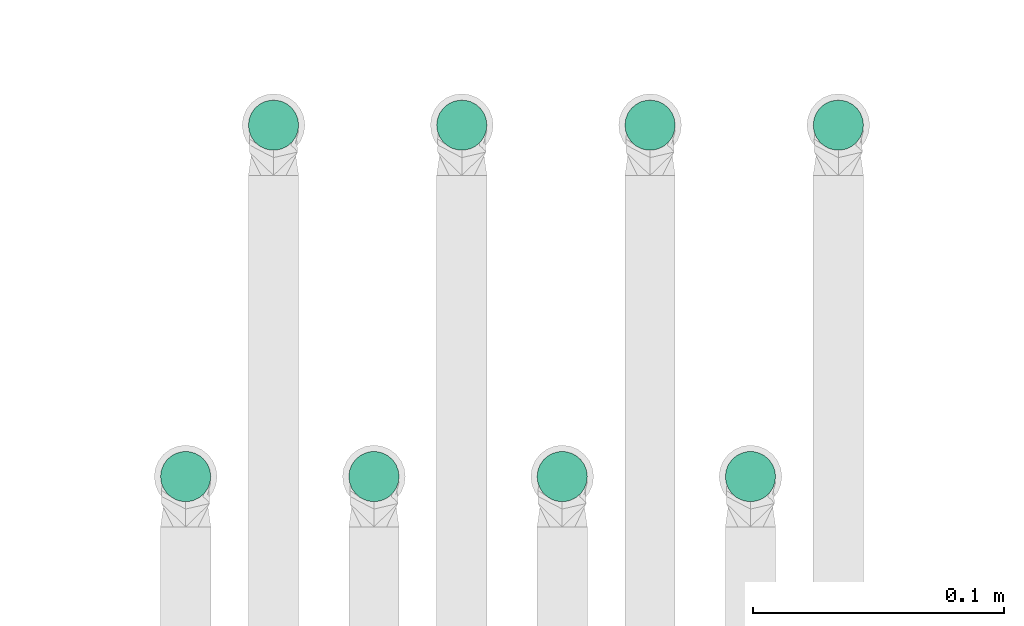
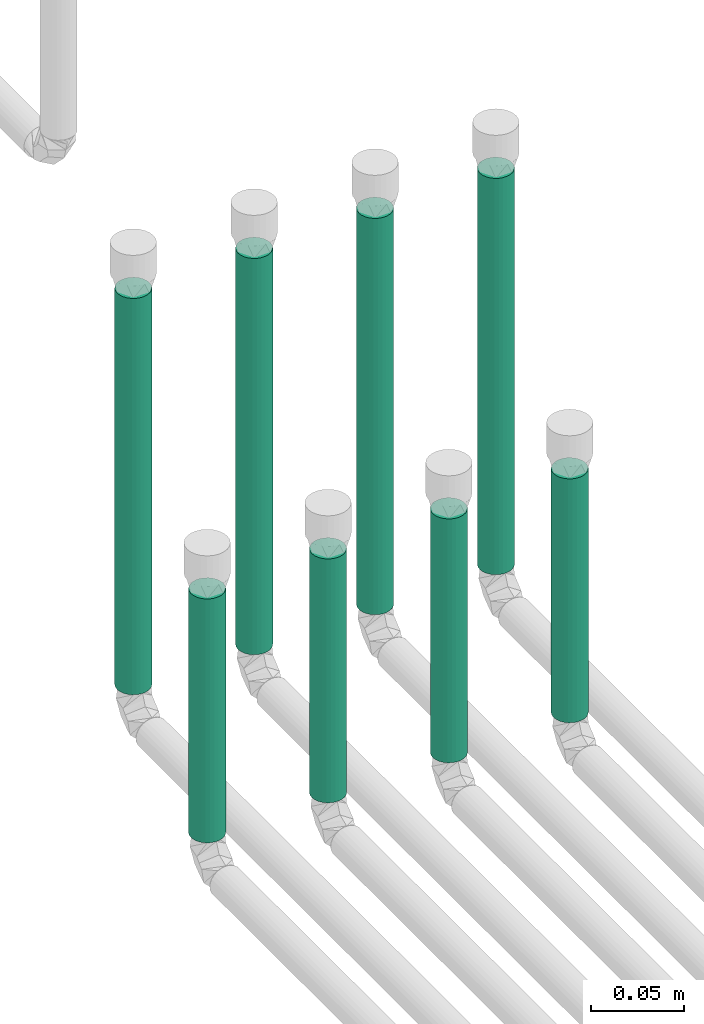
# One storey, part 4 of 12: 8 flow segments.
"""IFC2X3 building model written with IfcOpenShell, lengths in millimetres."""

from ifc_helpers import new_model, entity, si_unit, converted_unit, derived_unit, direction, frame, origin, origin_2d_with_axis, place, context, subcontext, project, spatial, circle, extrude, type_object, element, save


model = new_model("IFC2X3")

# Units and contexts
model_context = context("Model", 3, precision=0.01, world=origin(), true_north=direction((6.12303176911189e-17, 1.0)))
body_context = subcontext(model_context, "Body", "Model", "MODEL_VIEW")
ifc_project = project(units=[si_unit("LENGTHUNIT", "METRE", prefix="MILLI"), si_unit("AREAUNIT", "SQUARE_METRE"), si_unit("VOLUMEUNIT", "CUBIC_METRE"), converted_unit("PLANEANGLEUNIT", "DEGREE", entity("IfcRatioMeasure", 0.0174532925199433), si_unit("PLANEANGLEUNIT", "RADIAN"), dimensions=[0, 0, 0, 0, 0, 0, 0]), si_unit("MASSUNIT", "GRAM", prefix="KILO"), derived_unit("MASSDENSITYUNIT", [(si_unit("MASSUNIT", "GRAM", prefix="KILO"), 1), (si_unit("LENGTHUNIT", "METRE"), -3)]), si_unit("TIMEUNIT", "SECOND"), si_unit("FREQUENCYUNIT", "HERTZ"), si_unit("THERMODYNAMICTEMPERATUREUNIT", "DEGREE_CELSIUS"), derived_unit("THERMALTRANSMITTANCEUNIT", [(si_unit("MASSUNIT", "GRAM", prefix="KILO"), 1), (si_unit("THERMODYNAMICTEMPERATUREUNIT", "KELVIN"), -1), (si_unit("TIMEUNIT", "SECOND"), -3)]), derived_unit("VOLUMETRICFLOWRATEUNIT", [(si_unit("LENGTHUNIT", "METRE"), 3), (si_unit("TIMEUNIT", "SECOND"), -1)]), si_unit("ELECTRICCURRENTUNIT", "AMPERE"), si_unit("ELECTRICVOLTAGEUNIT", "VOLT"), si_unit("POWERUNIT", "WATT"), si_unit("FORCEUNIT", "NEWTON", prefix="KILO"), si_unit("ILLUMINANCEUNIT", "LUX"), si_unit("LUMINOUSFLUXUNIT", "LUMEN"), si_unit("LUMINOUSINTENSITYUNIT", "CANDELA"), derived_unit("USERDEFINED", [(si_unit("MASSUNIT", "GRAM", prefix="KILO"), -1), (si_unit("LENGTHUNIT", "METRE"), -2), (si_unit("TIMEUNIT", "SECOND"), 3), (si_unit("LUMINOUSFLUXUNIT", "LUMEN"), 1)]), derived_unit("LINEARVELOCITYUNIT", [(si_unit("LENGTHUNIT", "METRE"), 1), (si_unit("TIMEUNIT", "SECOND"), -1)]), si_unit("PRESSUREUNIT", "PASCAL"), derived_unit("USERDEFINED", [(si_unit("LENGTHUNIT", "METRE"), -2), (si_unit("MASSUNIT", "GRAM", prefix="KILO"), 1), (si_unit("TIMEUNIT", "SECOND"), -2)])], contexts=[model_context])

# Site, building, storey
site_placement = place(None, origin())
site = spatial("IfcSite", under=ifc_project, at=site_placement, CompositionType="ELEMENT")
building_placement = place(site_placement, origin())
building = spatial("IfcBuilding", under=site, at=building_placement, CompositionType="ELEMENT")
storey_placement = place(building_placement, frame((0.0, 0.0, 4000.0)))
storey = spatial("IfcBuildingStorey", under=building, at=storey_placement, Name="01 Level", CompositionType="ELEMENT", Elevation=4000.0)

# Flow segments
pipe_segment_type = type_object("IfcPipeSegmentType", PredefinedType="NOTDEFINED")
flow_segment_1_placement = place(storey_placement, frame((25764.4416997349, -69217.8348573758, -50.0)))
element("IfcFlowSegment", 1, at=flow_segment_1_placement, inside=storey, type_object=pipe_segment_type, context=body_context, shape_type="SweptSolid", body=[
    extrude(circle(Radius=10.0, at=origin_2d_with_axis()), frame((11.595272235918, 11.5952722359136, 0.0)), (0.0, 0.0, 1.0), 160.000000000009),
])
flow_segment_2_placement = place(storey_placement, frame((25799.4416997349, -69077.8348573759, -50.0)))
element("IfcFlowSegment", 2, at=flow_segment_2_placement, inside=storey, type_object=pipe_segment_type, context=body_context, shape_type="SweptSolid", body=[
    extrude(circle(Radius=10.0, at=origin_2d_with_axis()), frame((11.595272235918, 11.5952722359136, 0.0)), (0.0, 0.0, 1.0), 260.000000000014),
])
flow_segment_3_placement = place(storey_placement, frame((25839.4416997349, -69217.8348573758, -50.0)))
element("IfcFlowSegment", 3, at=flow_segment_3_placement, inside=storey, type_object=pipe_segment_type, context=body_context, shape_type="SweptSolid", body=[
    extrude(circle(Radius=10.0, at=origin_2d_with_axis()), frame((11.595272235918, 11.5952722359136, 0.0)), (0.0, 0.0, 1.0), 160.000000000014),
])
flow_segment_4_placement = place(storey_placement, frame((25874.4416997349, -69077.8348573759, -50.0)))
element("IfcFlowSegment", 4, at=flow_segment_4_placement, inside=storey, type_object=pipe_segment_type, context=body_context, shape_type="SweptSolid", body=[
    extrude(circle(Radius=10.0, at=origin_2d_with_axis()), frame((11.595272235918, 11.5952722359136, 0.0)), (0.0, 0.0, 1.0), 260.000000000015),
])
flow_segment_5_placement = place(storey_placement, frame((25914.4416997349, -69217.8348573758, -50.0)))
element("IfcFlowSegment", 5, at=flow_segment_5_placement, inside=storey, type_object=pipe_segment_type, context=body_context, shape_type="SweptSolid", body=[
    extrude(circle(Radius=10.0, at=origin_2d_with_axis()), frame((11.595272235918, 11.5952722359136, 0.0)), (0.0, 0.0, 1.0), 160.000000000016),
])
flow_segment_6_placement = place(storey_placement, frame((25949.4416997349, -69077.8348573759, -50.0)))
element("IfcFlowSegment", 6, at=flow_segment_6_placement, inside=storey, type_object=pipe_segment_type, context=body_context, shape_type="SweptSolid", body=[
    extrude(circle(Radius=10.0, at=origin_2d_with_axis()), frame((11.595272235918, 11.5952722359136, 0.0)), (0.0, 0.0, 1.0), 260.000000000014),
])
flow_segment_7_placement = place(storey_placement, frame((25989.4416997349, -69217.8348573758, -50.0)))
element("IfcFlowSegment", 7, at=flow_segment_7_placement, inside=storey, type_object=pipe_segment_type, context=body_context, shape_type="SweptSolid", body=[
    extrude(circle(Radius=10.0, at=origin_2d_with_axis()), frame((11.595272235918, 11.5952722359136, 0.0)), (0.0, 0.0, 1.0), 160.000000000015),
])
flow_segment_8_placement = place(storey_placement, frame((26024.4416997349, -69077.8348573759, -50.0)))
element("IfcFlowSegment", 8, at=flow_segment_8_placement, inside=storey, type_object=pipe_segment_type, context=body_context, shape_type="SweptSolid", body=[
    extrude(circle(Radius=10.0, at=origin_2d_with_axis()), frame((11.595272235918, 11.5952722359136, 0.0)), (0.0, 0.0, 1.0), 260.000000000016),
])

save(model, "model.ifc")
